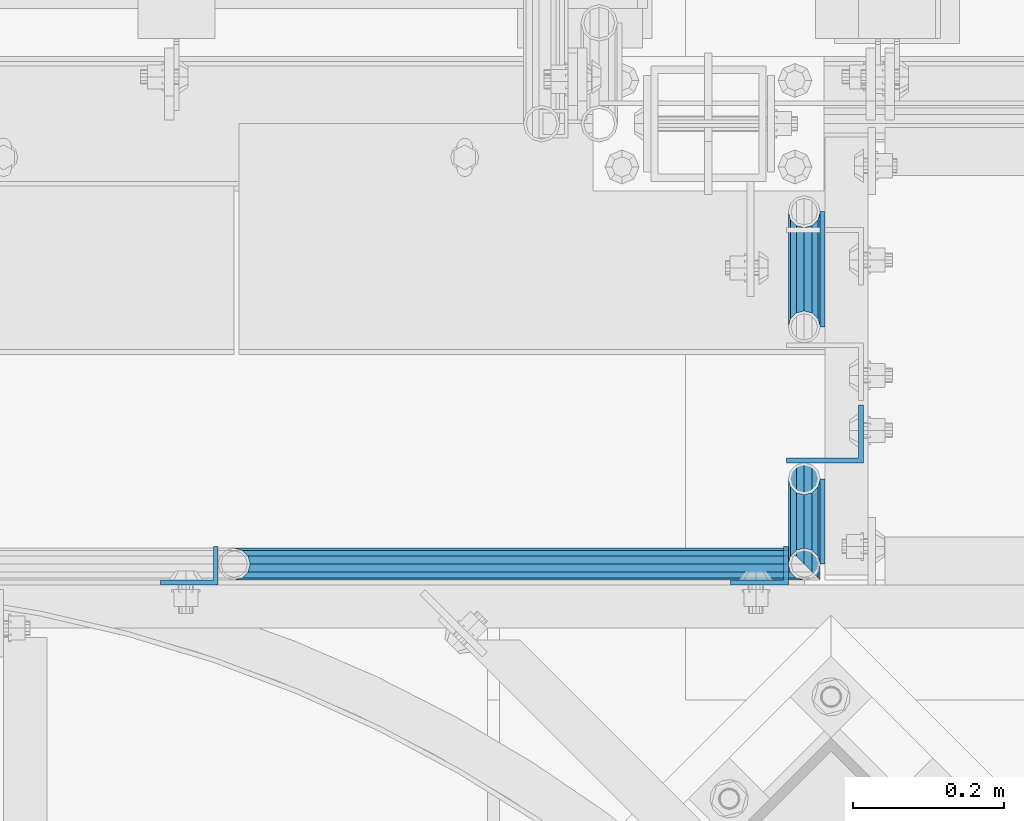
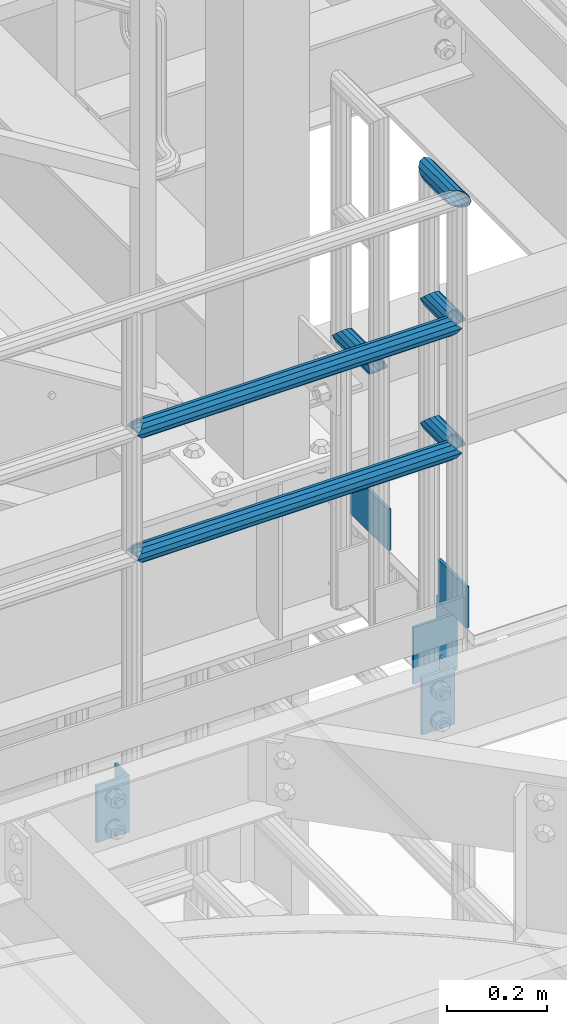
# One storey, part 1150 of 1876: 11 beams, 2 elements without a shape of their own.
"""IFC2X3 building model written with IfcOpenShell, lengths in millimetres."""

from ifc_helpers import new_model, si_unit, frame, origin_with_axes, place, context, subcontext, project, spatial, faceted_brep, material, type_object, element, aggregate, save


model = new_model("IFC2X3")

# Units and contexts
model_context = context("Model", 3, precision=1e-05, world=origin_with_axes())
body_context = subcontext(model_context, "Body", "Model", "MODEL_VIEW")
ifc_project = project(units=[si_unit("LENGTHUNIT", "METRE", prefix="MILLI"), si_unit("AREAUNIT", "SQUARE_METRE"), si_unit("VOLUMEUNIT", "CUBIC_METRE"), si_unit("MASSUNIT", "GRAM", prefix="KILO"), si_unit("TIMEUNIT", "SECOND"), si_unit("PLANEANGLEUNIT", "RADIAN"), si_unit("SOLIDANGLEUNIT", "STERADIAN"), si_unit("THERMODYNAMICTEMPERATUREUNIT", "DEGREE_CELSIUS"), si_unit("LUMINOUSINTENSITYUNIT", "LUMEN")], contexts=[model_context])

# Site, building, storey
site_placement = place(None, origin_with_axes())
site = spatial("IfcSite", under=ifc_project, at=site_placement, CompositionType="ELEMENT")
building_placement = place(site_placement, origin_with_axes())
building = spatial("IfcBuilding", under=site, at=building_placement, Name="Undefined", CompositionType="ELEMENT")
storey_placement = place(building_placement, origin_with_axes())
storey = spatial("IfcBuildingStorey", under=building, at=storey_placement, Name="Undefined", CompositionType="ELEMENT", Elevation=0.0)

# Assembly, beams
assembly_1_placement = place(storey_placement, origin_with_axes())
assembly_1 = element("IfcElementAssembly", 1, at=assembly_1_placement, inside=storey, Name="HANDRAIL", AssemblyPlace="NOTDEFINED", PredefinedType="RIGID_FRAME")
ifc_material_1 = material()
beam_type_1 = type_object("IfcBeamType", Name="PIPE1-1/4STD", PredefinedType="NOTDEFINED")
beam_1_placement = place(assembly_1_placement, frame((5791.20474593762, -7694.13240429563, 8480.425), z_axis=(0.0, 0.0, 1.0), x_axis=(1.0, 0.0, 0.0)))
beam_1 = element("IfcBeam", 2, at=beam_1_placement, type_object=beam_type_1, material=ifc_material_1, Name="RAIL", ObjectType="PIPE1-1/4STD", context=body_context, shape_type="Brep", body=[
    faceted_brep([(735.355706499795, -10.5410000000002, 18.2575475625836), (735.355706499795, -10.5410000000002, 13.3999612267253), (734.879292835652, -8.76299999999992, 15.1779612267255), (732.531254062378, 0.0, 17.5259999999998), (732.531254062378, 0.0, 21.0820000000003), (734.879292835652, 8.76299999999992, 15.1779612267255), (735.355706499795, 10.5410000000002, 13.3999612267253), (735.355706499795, 10.5410000000002, 18.2575475625836), (753.613254062378, 21.0820000000003, 0.0), (743.072254062378, 18.2575475625836, 10.5409999999993), (743.072254062378, 18.2575475625836, -10.5409999999993), (739.992667726521, 15.1779612267264, 8.76300000000083), (742.340706499795, 17.5259999999998, 0.0), (739.992667726521, 15.1779612267264, -8.76300000000083), (735.355706499795, 10.5410000000002, -13.3999612267253), (735.355706499795, 10.5410000000002, -18.2575475625836), (734.879292835652, 8.76299999999992, -15.1779612267255), (732.531254062378, 0.0, -17.5259999999998), (732.531254062378, 0.0, -21.0820000000003), (735.355706499795, -10.5410000000002, -13.3999612267253), (735.355706499795, -10.5410000000002, -18.2575475625836), (734.879292835652, -8.76299999999992, -15.1779612267255), (753.613254062378, -21.0820000000003, 0.0), (743.072254062378, -18.2575475625836, -10.5409999999993), (743.072254062378, -18.2575475625836, 10.5409999999993), (739.992667726521, -15.1779612267264, -8.76300000000083), (742.340706499795, -17.5259999999998, 0.0), (739.992667726521, -15.1779612267264, 8.76300000000083), (10.5409999957128, -18.2575475672238, -10.5409999999993), (18.2575475625817, -10.5410000000011, -18.2575475625836), (9.09494701772928e-13, 21.0820000000003, 0.0), (10.5409999957128, 18.2575475579433, -10.5409999999993), (10.5409999999983, 18.2575475625836, 10.5410000000011), (18.2575475625817, 10.5409999999993, 18.2575475625836), (21.0819999999985, 1.81898940354586e-12, 21.0820000000003), (18.2575475625817, 10.5409999999993, -18.2575475625836), (21.0819999999985, 0.0, -21.0819999999985), (21.0819999999985, 0.0, -17.5259999999998), (18.2575475625817, -10.5409999999974, -13.3999612267271), (18.7339612267233, -8.76300000000083, -15.1779612267255), (18.7339612267251, 8.76299999999901, -15.1779612267255), (18.2575475625817, 10.5410000000011, -13.3999612267235), (13.6205863358573, 15.1779612267255, -8.76299999999901), (11.2725475625839, 17.5259999999998, 0.0), (13.6205863358573, 15.1779612267255, 8.76300000000083), (18.2575475625817, 10.5410000000011, 13.3999612267253), (18.7339612267251, 8.76299999999901, 15.1779612267273), (21.0819999999985, 1.81898940354586e-12, 17.5259999999998), (18.7339612267233, -8.76300000000083, 15.1779612267273), (18.2575475625817, -10.5409999999974, 13.3999612267289), (18.2575475625817, -10.5410000000011, 18.2575475625836), (10.5409999999983, -18.2575475625836, 10.5410000000011), (9.09494701772928e-13, -21.0820000000003, 0.0), (13.6205863358537, -15.1779612267255, 8.76300000000083), (11.2725475625793, -17.5259999999998, 0.0), (13.6205863358537, -15.1779612267255, -8.76299999999901)], [[[0, 1, 2, 3, 4]], [[4, 3, 5, 6, 7]], [[8, 9, 10]], [[7, 6, 11, 12, 13, 14, 15, 10, 9]], [[16, 17, 18, 15, 14]], [[19, 20, 18, 17, 21]], [[22, 23, 24]], [[24, 23, 20, 19, 25, 26, 27, 1, 0]], [[28, 29, 20, 23]], [[30, 31, 32]], [[33, 34, 4, 7]], [[32, 33, 7, 9]], [[30, 32, 9, 8]], [[31, 30, 8, 10]], [[35, 31, 10, 15]], [[36, 35, 15, 18]], [[29, 36, 18, 20]], [[37, 36, 29, 38, 39]], [[40, 41, 35, 36, 37]], [[32, 31, 35, 41, 42, 43, 44, 45, 33]], [[33, 45, 46, 47, 34]], [[34, 47, 48, 49, 50]], [[34, 50, 0, 4]], [[50, 51, 24, 0]], [[51, 52, 22, 24]], [[52, 28, 23, 22]], [[51, 28, 52]], [[50, 49, 53, 54, 55, 38, 29, 28, 51]], [[55, 54, 26, 25]], [[21, 39, 38, 55, 25, 19]], [[37, 39, 21, 17]], [[40, 37, 17, 16]], [[42, 41, 40, 16, 14, 13]], [[43, 42, 13, 12]], [[44, 43, 12, 11]], [[5, 46, 45, 44, 11, 6]], [[47, 46, 5, 3]], [[48, 47, 3, 2]], [[53, 49, 48, 2, 1, 27]], [[54, 53, 27, 26]]]),
])
beam_2_placement = place(assembly_1_placement, frame((6544.818, -7694.13240429563, 8785.225), z_axis=(0.0, 0.0, -1.0), x_axis=(-1.0, 0.0, 0.0)))
beam_2 = element("IfcBeam", 3, at=beam_2_placement, type_object=beam_type_1, material=ifc_material_1, Name="RAIL", ObjectType="PIPE1-1/4STD", context=body_context, shape_type="Brep", body=[
    faceted_brep([(9.09494701772928e-13, 21.0820000000003, 0.0), (10.5409999957128, 18.2575475579433, -10.5409999999993), (10.5409999999983, 18.2575475625836, 10.5410000000011), (10.5409999999983, -18.2575475625836, 10.5410000000011), (10.5409999957128, -18.2575475672238, -10.5409999999993), (9.09494701772928e-13, -21.0820000000003, 0.0), (18.2575475625817, -10.5410000000011, 18.2575475625836), (18.2575475625817, -10.5409999999974, 13.3999612267289), (13.6205863358537, -15.1779612267255, 8.76300000000083), (11.2725475625793, -17.5259999999998, 0.0), (13.6205863358537, -15.1779612267255, -8.76299999999901), (18.2575475625817, -10.5409999999974, -13.3999612267271), (18.2575475625817, -10.5410000000011, -18.2575475625836), (21.0819999999985, 0.0, -17.5259999999998), (21.0819999999985, 0.0, -21.0819999999985), (18.7339612267233, -8.76300000000083, -15.1779612267255), (18.7339612267251, 8.76299999999901, -15.1779612267255), (18.2575475625817, 10.5410000000011, -13.3999612267235), (18.2575475625817, 10.5409999999993, -18.2575475625836), (13.6205863358573, 15.1779612267255, -8.76299999999901), (11.2725475625839, 17.5259999999998, 0.0), (13.6205863358573, 15.1779612267255, 8.76300000000083), (18.2575475625817, 10.5410000000011, 13.3999612267253), (18.2575475625817, 10.5409999999993, 18.2575475625836), (18.7339612267251, 8.76299999999901, 15.1779612267273), (21.0819999999985, 1.81898940354586e-12, 17.5259999999998), (21.0819999999985, 1.81898940354586e-12, 21.0820000000003), (18.7339612267233, -8.76300000000083, 15.1779612267273), (753.613254062378, 21.0820000000003, 0.0), (743.072254062378, 18.2575475625836, -10.5409999999993), (735.355706499795, 10.5410000000002, -18.2575475625836), (753.613254062378, -21.0820000000003, 0.0), (743.072254062378, -18.2575475625836, -10.5409999999993), (743.072254062378, -18.2575475625836, 10.5409999999993), (735.355706499795, -10.5410000000002, 18.2575475625836), (735.355706499795, -10.5410000000002, -18.2575475625836), (732.531254062378, 0.0, -21.0820000000003), (734.879292835652, 8.76299999999992, -15.1779612267255), (732.531254062378, 0.0, -17.5259999999998), (735.355706499795, 10.5410000000002, -13.3999612267253), (735.355706499795, -10.5410000000002, -13.3999612267253), (734.879292835652, -8.76299999999992, -15.1779612267255), (739.992667726521, -15.1779612267264, -8.76300000000083), (742.340706499795, -17.5259999999998, 0.0), (739.992667726521, -15.1779612267264, 8.76300000000083), (735.355706499795, -10.5410000000002, 13.3999612267253), (734.879292835652, -8.76299999999992, 15.1779612267255), (732.531254062378, 0.0, 17.5259999999998), (732.531254062378, 0.0, 21.0820000000003), (735.355706499795, 10.5410000000002, 18.2575475625836), (743.072254062378, 18.2575475625836, 10.5409999999993), (735.355706499795, 10.5410000000002, 13.3999612267253), (739.992667726521, 15.1779612267264, 8.76300000000083), (742.340706499795, 17.5259999999998, 0.0), (739.992667726521, 15.1779612267264, -8.76300000000083), (734.879292835652, 8.76299999999992, 15.1779612267255)], [[[0, 1, 2]], [[3, 4, 5]], [[6, 7, 8, 9, 10, 11, 12, 4, 3]], [[13, 14, 12, 11, 15]], [[16, 17, 18, 14, 13]], [[2, 1, 18, 17, 19, 20, 21, 22, 23]], [[23, 22, 24, 25, 26]], [[26, 25, 27, 7, 6]], [[1, 0, 28, 29]], [[18, 1, 29, 30]], [[31, 32, 33]], [[6, 3, 33, 34]], [[3, 5, 31, 33]], [[5, 4, 32, 31]], [[4, 12, 35, 32]], [[12, 14, 36, 35]], [[14, 18, 30, 36]], [[37, 38, 36, 30, 39]], [[40, 35, 36, 38, 41]], [[33, 32, 35, 40, 42, 43, 44, 45, 34]], [[34, 45, 46, 47, 48]], [[26, 6, 34, 48]], [[2, 23, 49, 50]], [[23, 26, 48, 49]], [[0, 2, 50, 28]], [[28, 50, 29]], [[49, 51, 52, 53, 54, 39, 30, 29, 50]], [[48, 47, 55, 51, 49]], [[25, 24, 55, 47]], [[55, 24, 22, 21, 52, 51]], [[21, 20, 53, 52]], [[20, 19, 54, 53]], [[19, 17, 16, 37, 39, 54]], [[16, 13, 38, 37]], [[13, 15, 41, 38]], [[41, 15, 11, 10, 42, 40]], [[10, 9, 43, 42]], [[9, 8, 44, 43]], [[8, 7, 27, 46, 45, 44]], [[27, 25, 47, 46]]]),
])
beam_3_placement = place(assembly_1_placement, frame((6544.81341817141, -7694.215625, 8480.42499999999), z_axis=(0.0, 0.0, -1.0), x_axis=(0.0, 1.0, 0.0)))
beam_3 = element("IfcBeam", 4, at=beam_3_placement, type_object=beam_type_1, material=ifc_material_1, Name="RAIL", ObjectType="PIPE1-1/4STD", context=body_context, shape_type="Brep", body=[
    faceted_brep([(94.5399051925961, -10.5410000000002, 18.2575475625836), (94.5399051925961, -10.5354181714065, 13.4055430553199), (94.0649871749174, -8.76299999999992, 15.1779612267255), (91.7157205279746, 0.00105404684563837, 17.5259999999998), (91.7157205279746, 0.00105404684563837, 21.0820000000003), (94.0625317803742, 8.76299999999992, 15.1779612267255), (94.5399051925961, 10.5445818285934, 13.3963793981329), (94.5399051925961, 10.5410000000002, 18.2575475625836), (112.795720704372, 21.0820000000003, 0.0), (102.255720704372, 18.2575475625836, 10.5409999999993), (102.255720704372, 18.2575475625836, -10.5409999999993), (99.1732845907281, 15.1779612267264, 8.76300000000083), (101.521323364002, 17.5259999999998, 0.0), (99.1732845907281, 15.1779612267264, -8.76300000000083), (94.5399051925961, 10.5445818285934, -13.3963793981329), (94.5399051925961, 10.5410000000002, -18.2575475625836), (94.0625317803742, 8.76299999999992, -15.1779612267255), (91.715720704372, 0.0, -17.5259999999998), (91.715720704372, 0.0, -21.0820000000003), (94.5399051925961, -10.5354181714065, -13.4055430553199), (94.5399051925961, -10.5410000000002, -18.2575475625836), (94.0649871749174, -8.76299999999992, -15.1779612267255), (112.795720704372, -21.0754181714065, 0.0), (102.255720704372, -18.2575475625836, -10.5409999999993), (102.255720704372, -18.2575475625836, 10.5409999999993), (99.1824482479151, -15.1779612267264, -8.76300000000083), (101.530487021189, -17.5259999999998, 0.0), (99.1824482479151, -15.1779612267264, 8.76300000000083), (10.6232207043722, -18.2575475625836, -10.5409999999993), (18.3390362161481, -10.5410000000002, -18.2575475625836), (0.0832207043722519, 21.0820000000003, 0.0), (10.6232207043722, 18.2575475625836, -10.5409999999993), (10.6232207043722, 18.2575475625836, 10.5409999999993), (18.3390362161481, 10.5410000000002, 18.2575475625836), (21.1632207043722, 0.00458182859347289, 21.0820000000003), (18.3390362161481, 10.5410000000002, -18.2575475625836), (21.1632207043722, 0.0, -21.0820000000003), (21.1632207043722, 0.0, -17.5259999999998), (18.3390362161481, -10.5354181714065, -13.4055430553199), (18.8139542338267, -8.76299999999992, -15.1779612267255), (18.8164096283699, 8.76299999999992, -15.1779612267255), (18.3390362161481, 10.5445818285934, -13.3963793981329), (13.705656818016, 15.1779612267264, -8.76300000000083), (11.3576180447417, 17.5259999999998, 0.0), (13.705656818016, 15.1779612267264, 8.76300000000083), (18.3390362161481, 10.5445818285934, 13.3963793981329), (18.8164096283699, 8.76299999999992, 15.1779612267255), (21.1632207043722, 0.00458182859347289, 17.5259999999998), (18.8139542338267, -8.76299999999992, 15.1779612267255), (18.3390362161481, -10.5354181714065, 13.4055430553199), (18.3390362161481, -10.5410000000002, 18.2575475625836), (10.6232207043722, -18.2575475625836, 10.5409999999993), (0.0832207043722519, -21.0820000000003, 0.0), (13.696493160829, -15.1779612267264, 8.76300000000083), (11.3484543875547, -17.5259999999998, 0.0), (13.696493160829, -15.1779612267264, -8.76300000000083)], [[[0, 1, 2, 3, 4]], [[4, 3, 5, 6, 7]], [[8, 9, 10]], [[7, 6, 11, 12, 13, 14, 15, 10, 9]], [[16, 17, 18, 15, 14]], [[19, 20, 18, 17, 21]], [[22, 23, 24]], [[24, 23, 20, 19, 25, 26, 27, 1, 0]], [[28, 29, 20, 23]], [[30, 31, 32]], [[33, 34, 4, 7]], [[32, 33, 7, 9]], [[30, 32, 9, 8]], [[31, 30, 8, 10]], [[35, 31, 10, 15]], [[36, 35, 15, 18]], [[29, 36, 18, 20]], [[37, 36, 29, 38, 39]], [[40, 41, 35, 36, 37]], [[32, 31, 35, 41, 42, 43, 44, 45, 33]], [[33, 45, 46, 47, 34]], [[34, 47, 48, 49, 50]], [[34, 50, 0, 4]], [[50, 51, 24, 0]], [[51, 52, 22, 24]], [[52, 28, 23, 22]], [[51, 28, 52]], [[50, 49, 53, 54, 55, 38, 29, 28, 51]], [[55, 54, 26, 25]], [[21, 39, 38, 55, 25, 19]], [[37, 39, 21, 17]], [[40, 37, 17, 16]], [[42, 41, 40, 16, 14, 13]], [[43, 42, 13, 12]], [[44, 43, 12, 11]], [[5, 46, 45, 44, 11, 6]], [[47, 46, 5, 3]], [[48, 47, 3, 2]], [[53, 49, 48, 2, 1, 27]], [[54, 53, 27, 26]]]),
])
beam_4_placement = place(assembly_1_placement, frame((6544.81341817141, -7694.215625, 8785.22499999999), z_axis=(0.0, 0.0, -1.0), x_axis=(0.0, 1.0, 0.0)))
beam_4 = element("IfcBeam", 5, at=beam_4_placement, type_object=beam_type_1, material=ifc_material_1, Name="RAIL", ObjectType="PIPE1-1/4STD", context=body_context, shape_type="Brep", body=[
    faceted_brep([(94.5399051925961, -10.5410000000002, 18.2575475625836), (94.5399051925961, -10.5354181714065, 13.4055430553199), (94.0649871749174, -8.76299999999992, 15.1779612267255), (91.7157205279746, 0.00105404684563837, 17.5259999999998), (91.7157205279746, 0.00105404684563837, 21.0820000000003), (94.0625317803742, 8.76299999999992, 15.1779612267255), (94.5399051925961, 10.5445818285934, 13.3963793981329), (94.5399051925961, 10.5410000000002, 18.2575475625836), (112.795720704372, 21.0820000000003, 0.0), (102.255720704372, 18.2575475625836, 10.5409999999993), (102.255720704372, 18.2575475625836, -10.5409999999993), (99.1732845907281, 15.1779612267264, 8.76300000000083), (101.521323364002, 17.5259999999998, 0.0), (99.1732845907281, 15.1779612267264, -8.76300000000083), (94.5399051925961, 10.5445818285934, -13.3963793981329), (94.5399051925961, 10.5410000000002, -18.2575475625836), (94.0625317803742, 8.76299999999992, -15.1779612267255), (91.715720704372, 0.0, -17.5259999999998), (91.715720704372, 0.0, -21.0820000000003), (94.5399051925961, -10.5354181714065, -13.4055430553199), (94.5399051925961, -10.5410000000002, -18.2575475625836), (94.0649871749174, -8.76299999999992, -15.1779612267255), (112.795720704372, -21.0754181714065, 0.0), (102.255720704372, -18.2575475625836, -10.5409999999993), (102.255720704372, -18.2575475625836, 10.5409999999993), (99.1824482479151, -15.1779612267264, -8.76300000000083), (101.530487021189, -17.5259999999998, 0.0), (99.1824482479151, -15.1779612267264, 8.76300000000083), (10.6232207043722, -18.2575475625836, -10.5409999999993), (18.3390362161481, -10.5410000000002, -18.2575475625836), (0.0832207043722519, 21.0820000000003, 0.0), (10.6232207043722, 18.2575475625836, -10.5409999999993), (10.6232207043722, 18.2575475625836, 10.5409999999993), (18.3390362161481, 10.5410000000002, 18.2575475625836), (21.1632207043722, 0.00458182859347289, 21.0820000000003), (18.3390362161481, 10.5410000000002, -18.2575475625836), (21.1632207043722, 0.0, -21.0820000000003), (21.1632207043722, 0.0, -17.5259999999998), (18.3390362161481, -10.5354181714065, -13.4055430553199), (18.8139542338267, -8.76299999999992, -15.1779612267255), (18.8164096283699, 8.76299999999992, -15.1779612267255), (18.3390362161481, 10.5445818285934, -13.3963793981329), (13.705656818016, 15.1779612267264, -8.76300000000083), (11.3576180447417, 17.5259999999998, 0.0), (13.705656818016, 15.1779612267264, 8.76300000000083), (18.3390362161481, 10.5445818285934, 13.3963793981329), (18.8164096283699, 8.76299999999992, 15.1779612267255), (21.1632207043722, 0.00458182859347289, 17.5259999999998), (18.8139542338267, -8.76299999999992, 15.1779612267255), (18.3390362161481, -10.5354181714065, 13.4055430553199), (18.3390362161481, -10.5410000000002, 18.2575475625836), (10.6232207043722, -18.2575475625836, 10.5409999999993), (0.0832207043722519, -21.0820000000003, 0.0), (13.696493160829, -15.1779612267264, 8.76300000000083), (11.3484543875547, -17.5259999999998, 0.0), (13.696493160829, -15.1779612267264, -8.76300000000083)], [[[0, 1, 2, 3, 4]], [[4, 3, 5, 6, 7]], [[8, 9, 10]], [[7, 6, 11, 12, 13, 14, 15, 10, 9]], [[16, 17, 18, 15, 14]], [[19, 20, 18, 17, 21]], [[22, 23, 24]], [[24, 23, 20, 19, 25, 26, 27, 1, 0]], [[28, 29, 20, 23]], [[30, 31, 32]], [[33, 34, 4, 7]], [[32, 33, 7, 9]], [[30, 32, 9, 8]], [[31, 30, 8, 10]], [[35, 31, 10, 15]], [[36, 35, 15, 18]], [[29, 36, 18, 20]], [[37, 36, 29, 38, 39]], [[40, 41, 35, 36, 37]], [[32, 31, 35, 41, 42, 43, 44, 45, 33]], [[33, 45, 46, 47, 34]], [[34, 47, 48, 49, 50]], [[34, 50, 0, 4]], [[50, 51, 24, 0]], [[51, 52, 22, 24]], [[52, 28, 23, 22]], [[51, 28, 52]], [[50, 49, 53, 54, 55, 38, 29, 28, 51]], [[55, 54, 26, 25]], [[21, 39, 38, 55, 25, 19]], [[37, 39, 21, 17]], [[40, 37, 17, 16]], [[42, 41, 40, 16, 14, 13]], [[43, 42, 13, 12]], [[44, 43, 12, 11]], [[5, 46, 45, 44, 11, 6]], [[47, 46, 5, 3]], [[48, 47, 3, 2]], [[53, 49, 48, 2, 1, 27]], [[54, 53, 27, 26]]]),
])
beam_5_placement = place(assembly_1_placement, frame((6544.81341817141, -7694.13240429563, 9090.02499999999), z_axis=(0.0, 0.0, -1.0), x_axis=(0.0, 1.0, 0.0)))
beam_5 = element("IfcBeam", 6, at=beam_5_placement, type_object=beam_type_1, material=ifc_material_1, Name="RAIL", ObjectType="PIPE1-1/4STD", context=body_context, shape_type="Brep", body=[
    faceted_brep([(17.5259999999998, -17.5259999999998, 0.0), (15.1779612267264, -15.1779612267264, 8.76300000000083), (103.9495, -15.1779612267264, 8.76300000000083), (112.7125, -17.5259999999998, 0.0), (8.76299999999992, -8.76299999999992, 15.1779612267255), (97.5345387732732, -8.76299999999992, 15.1779612267255), (0.0, 0.0, 17.5259999999998), (95.1864999999998, 0.0, 17.5259999999998), (-8.76299999999992, 8.76299999999992, 15.1779612267255), (97.5345387732732, 8.76299999999992, 15.1779612267255), (-15.1779612267264, 15.1779612267264, 8.76300000000083), (103.9495, 15.1779612267264, 8.76300000000083), (-17.5259999999998, 17.5259999999998, 0.0), (112.7125, 17.5259999999998, 0.0), (-15.1779612267264, 15.1779612267264, -8.76300000000083), (121.4755, 15.1779612267264, -8.76300000000083), (-8.76299999999992, 8.76299999999992, -15.1779612267255), (127.890461226726, 8.76299999999992, -15.1779612267255), (0.0, 0.0, -17.5259999999998), (130.238499999999, 0.0, -17.5259999999998), (8.76299999999992, -8.76299999999992, -15.1779612267255), (127.890461226726, -8.76299999999992, -15.1779612267255), (15.1779612267264, -15.1779612267264, -8.76300000000083), (121.4755, -15.1779612267264, -8.76300000000083), (21.0819999957121, -21.0820000092799, 0.0), (18.2575475625836, -18.2575475625836, -10.5409999999993), (123.2535, -18.2575475625836, -10.5409999999993), (112.7125, -21.0820000000003, 0.0), (10.5410000000002, -10.5410000000002, -18.2575475625836), (130.970047562583, -10.5410000000002, -18.2575475625836), (-4.28826751885936e-09, 0.0, -21.0820000000003), (133.7945, 0.0, -21.0820000000003), (-10.5410000000002, 10.5410000000002, -18.2575475625836), (130.970047562583, 10.5410000000002, -18.2575475625836), (-18.2575475625836, 18.2575475625836, -10.5409999999993), (123.2535, 18.2575475625836, -10.5409999999993), (-21.0820000000003, 21.0820000000003, 0.0), (112.7125, 21.0820000000003, 0.0), (-18.2575475625836, 18.2575475625836, 10.5409999999993), (102.171499999999, 18.2575475625836, 10.5409999999993), (-10.5410000000002, 10.5410000000002, 18.2575475625836), (94.4549524374161, 10.5410000000002, 18.2575475625836), (0.0, 0.0, 21.0820000000003), (91.6304999999993, 0.0, 21.0820000000003), (10.5410000000002, -10.5410000000002, 18.2575475625836), (94.4549524374161, -10.5410000000002, 18.2575475625836), (18.2575475625836, -18.2575475625836, 10.5409999999993), (102.171499999999, -18.2575475625836, 10.5409999999993)], [[[0, 1, 2, 3]], [[1, 4, 5, 2]], [[4, 6, 7, 5]], [[6, 8, 9, 7]], [[8, 10, 11, 9]], [[10, 12, 13, 11]], [[12, 14, 15, 13]], [[14, 16, 17, 15]], [[16, 18, 19, 17]], [[18, 20, 21, 19]], [[20, 22, 23, 21]], [[22, 0, 3, 23]], [[24, 25, 26, 27]], [[25, 28, 29, 26]], [[28, 30, 31, 29]], [[30, 32, 33, 31]], [[32, 34, 35, 33]], [[34, 36, 37, 35]], [[36, 38, 39, 37]], [[38, 40, 41, 39]], [[40, 42, 43, 41]], [[42, 44, 45, 43]], [[44, 46, 47, 45]], [[46, 24, 27, 47]], [[29, 31, 33, 35, 37, 39, 41, 43, 45, 47, 27, 26], [5, 7, 9, 11, 13, 15, 17, 19, 21, 23, 3, 2]], [[46, 44, 42, 40, 38, 36, 34, 32, 30, 28, 25, 24], [22, 20, 18, 16, 14, 12, 10, 8, 6, 4, 1, 0]]]),
])

assembly_2_placement = place(storey_placement, origin_with_axes())
assembly_2 = element("IfcElementAssembly", 7, at=assembly_2_placement, inside=storey, Name="RAIL", AssemblyPlace="NOTDEFINED", PredefinedType="RIGID_FRAME")
beam_6_placement = place(assembly_2_placement, frame((6544.818, -7380.684375, 8480.42499999999), z_axis=(0.0, 0.0, -1.0), x_axis=(0.0, 1.0, 0.0)))
beam_6 = element("IfcBeam", 8, at=beam_6_placement, type_object=beam_type_1, material=ifc_material_1, Name="RAIL", ObjectType="PIPE1-1/4STD", context=body_context, shape_type="Brep", body=[
    faceted_brep([(134.227405192596, -10.5410000000002, 18.2575475625836), (134.227405192596, -10.54, 13.4009612267255), (133.751259477646, -8.76299999999992, 15.1779612267255), (131.403220704372, 0.0, 17.5259999999998), (131.403220704372, 0.0, 21.0820000000003), (133.751259477646, 8.76299999999992, 15.1779612267255), (134.227405192596, 10.54, 13.4009612267255), (134.227405192596, 10.5410000000002, 18.2575475625836), (152.483220704372, 21.0820000000003, 0.0), (141.943220704372, 18.2575475625836, 10.5409999999993), (141.943220704372, 18.2575475625836, -10.5409999999993), (138.865366419322, 15.1779612267264, 8.76300000000083), (141.213405192596, 17.5259999999998, 0.0), (138.865366419322, 15.1779612267264, -8.76300000000083), (134.227405192596, 10.54, -13.4009612267255), (134.227405192596, 10.5410000000002, -18.2575475625836), (133.751259477646, 8.76299999999992, -15.1779612267255), (131.403220704372, 0.0, -17.5259999999998), (131.403220704372, 0.0, -21.0820000000003), (134.227405192596, -10.54, -13.4009612267255), (134.227405192596, -10.5410000000002, -18.2575475625836), (133.751259477646, -8.76299999999992, -15.1779612267255), (152.483220704372, -21.0799999999999, 0.0), (141.943220704372, -18.2575475625836, -10.5409999999993), (141.943220704372, -18.2575475625836, 10.5409999999993), (138.865366419322, -15.1779612267264, -8.76300000000083), (141.213405192596, -17.5259999999998, 0.0), (138.865366419322, -15.1779612267264, 8.76300000000083), (10.6232207043722, -18.2575475625836, -10.5409999999993), (18.3390362161481, -10.5410000000002, -18.2575475625836), (0.0832207043722519, 21.0820000000003, 0.0), (10.6232207043722, 18.2575475625836, -10.5409999999993), (10.6232207043722, 18.2575475625836, 10.5409999999993), (18.3390362161481, 10.5410000000002, 18.2575475625836), (21.1632207043722, 0.0, 21.0820000000003), (18.3390362161481, 10.5410000000002, -18.2575475625836), (21.1632207043722, 0.0, -21.0820000000003), (21.1632207043722, 0.0, -17.5259999999998), (18.3390362161481, -10.54, -13.4009612267255), (18.8151819310979, -8.76299999999992, -15.1779612267255), (18.8151819310979, 8.76299999999992, -15.1779612267255), (18.3390362161481, 10.54, -13.4009612267255), (13.7010749894225, 15.1779612267264, -8.76300000000083), (11.3530362161482, 17.5259999999998, 0.0), (13.7010749894225, 15.1779612267264, 8.76300000000083), (18.3390362161481, 10.54, 13.4009612267255), (18.8151819310979, 8.76299999999992, 15.1779612267255), (21.1632207043722, 0.0, 17.5259999999998), (18.8151819310979, -8.76299999999992, 15.1779612267255), (18.3390362161481, -10.54, 13.4009612267255), (18.3390362161481, -10.5410000000002, 18.2575475625836), (10.6232207043722, -18.2575475625836, 10.5409999999993), (0.0832207043722519, -21.0820000000003, 0.0), (13.7010749894225, -15.1779612267264, 8.76300000000083), (11.3530362161482, -17.5259999999998, 0.0), (13.7010749894225, -15.1779612267264, -8.76300000000083)], [[[0, 1, 2, 3, 4]], [[4, 3, 5, 6, 7]], [[8, 9, 10]], [[7, 6, 11, 12, 13, 14, 15, 10, 9]], [[16, 17, 18, 15, 14]], [[19, 20, 18, 17, 21]], [[22, 23, 24]], [[24, 23, 20, 19, 25, 26, 27, 1, 0]], [[28, 29, 20, 23]], [[30, 31, 32]], [[33, 34, 4, 7]], [[32, 33, 7, 9]], [[30, 32, 9, 8]], [[31, 30, 8, 10]], [[35, 31, 10, 15]], [[36, 35, 15, 18]], [[29, 36, 18, 20]], [[37, 36, 29, 38, 39]], [[40, 41, 35, 36, 37]], [[32, 31, 35, 41, 42, 43, 44, 45, 33]], [[33, 45, 46, 47, 34]], [[34, 47, 48, 49, 50]], [[34, 50, 0, 4]], [[50, 51, 24, 0]], [[51, 52, 22, 24]], [[52, 28, 23, 22]], [[51, 28, 52]], [[50, 49, 53, 54, 55, 38, 29, 28, 51]], [[55, 54, 26, 25]], [[21, 39, 38, 55, 25, 19]], [[37, 39, 21, 17]], [[40, 37, 17, 16]], [[42, 41, 40, 16, 14, 13]], [[43, 42, 13, 12]], [[44, 43, 12, 11]], [[5, 46, 45, 44, 11, 6]], [[47, 46, 5, 3]], [[48, 47, 3, 2]], [[53, 49, 48, 2, 1, 27]], [[54, 53, 27, 26]]]),
])
ifc_material_2 = material(Name="STEEL/A36")
beam_type_2 = type_object("IfcBeamType", PredefinedType="NOTDEFINED")
beam_7_placement = place(assembly_2_placement, frame((6569.075, -7380.60115429563, 8080.375), z_axis=(0.0, 0.0, 1.0), x_axis=(0.0, 1.0, 0.0)))
beam_7 = element("IfcBeam", 9, at=beam_7_placement, type_object=beam_type_2, material=ifc_material_2, Name="PLATE", context=body_context, shape_type="Brep", body=[
    faceted_brep([(0.0, 3.17500000000018, -50.8000000000002), (0.0, 3.17500000000018, 50.8000000000002), (152.400000000001, 3.17500000000018, 50.8000000000002), (152.400000000001, 3.17500000000018, -50.8000000000002), (0.0, -3.17500000000018, 50.8000000000002), (152.400000000001, -3.17500000000018, 50.8000000000002), (0.0, -3.17500000000018, -50.8000000000002), (152.400000000001, -3.17500000000018, -50.8000000000002)], [[[0, 1, 2, 3]], [[1, 4, 5, 2]], [[4, 6, 7, 5]], [[6, 0, 3, 7]], [[5, 7, 3, 2]], [[6, 4, 1, 0]]]),
])
aggregate(assembly_2, [beam_7, beam_6])

# Beam
beam_8_placement = place(assembly_1_placement, frame((6569.075, -7694.13240429563, 8080.375), z_axis=(0.0, 0.0, 1.0), x_axis=(0.0, 1.0, 0.0)))
beam_8 = element("IfcBeam", 10, at=beam_8_placement, type_object=beam_type_2, material=ifc_material_2, Name="PLATE", context=body_context, shape_type="Brep", body=[
    faceted_brep([(0.0, 3.17500000000018, -50.8000000000002), (0.0, 3.17500000000018, 50.8000000000002), (112.712500000001, 3.17500000000018, 50.8000000000002), (112.712500000001, 3.17500000000018, -50.8000000000002), (0.0, -3.17500000000018, 50.8000000000002), (112.712500000001, -3.17500000000018, 50.8000000000002), (0.0, -3.17500000000018, -50.8000000000002), (112.712500000001, -3.17500000000018, -50.8000000000002)], [[[0, 1, 2, 3]], [[1, 4, 5, 2]], [[4, 6, 7, 5]], [[6, 0, 3, 7]], [[5, 7, 3, 2]], [[6, 4, 1, 0]]]),
])

beam_type_3 = type_object("IfcBeamType", Name="L4X3X1/4", PredefinedType="NOTDEFINED")
beam_9_placement = place(assembly_1_placement, frame((6572.25, -7522.23790429563, 7966.075), z_axis=(-1.0, 0.0, 0.0), x_axis=(0.0, 0.0, -1.0)))
beam_9 = element("IfcBeam", 11, at=beam_9_placement, type_object=beam_type_3, material=ifc_material_2, Name="ANGLE", ObjectType="L4X3X1/4", context=body_context, shape_type="Brep", body=[
    faceted_brep([(0.0, 38.1000000000004, -50.8000000000002), (0.0, 38.1000000000004, 50.8000000000002), (139.7, 38.1000000000004, 50.8000000000002), (139.7, 38.1000000000004, -50.8000000000002), (0.0, 31.75, 50.8000000000002), (139.7, 31.75, 50.8000000000002), (0.0, 31.75, -44.4499999999998), (139.7, 31.75, -44.4499999999998), (0.0, -38.1000000000004, -44.4499999999998), (139.7, -38.1000000000004, -44.4499999999998), (0.0, -38.1000000000004, -50.8000000000002), (139.7, -38.1000000000004, -50.8000000000002)], [[[0, 1, 2, 3]], [[1, 4, 5, 2]], [[4, 6, 7, 5]], [[6, 8, 9, 7]], [[8, 10, 11, 9]], [[10, 0, 3, 11]], [[5, 7, 9, 11, 3, 2]], [[10, 8, 6, 4, 1, 0]]]),
])

beam_type_4 = type_object("IfcBeamType", Name="L3X2X1/4", PredefinedType="NOTDEFINED")
beam_10_placement = place(assembly_1_placement, frame((6485.636, -7696.16440429563, 7966.075), z_axis=(-1.0, 0.0, 0.0), x_axis=(0.0, 0.0, -1.0)))
beam_10 = element("IfcBeam", 12, at=beam_10_placement, type_object=beam_type_4, material=ifc_material_2, Name="ANGLE", ObjectType="L3X2X1/4", context=body_context, shape_type="Brep", body=[
    faceted_brep([(0.0, 25.3999999999996, -38.1000000000004), (0.0, 25.3999999999996, 38.1000000000004), (139.7, 25.3999999999996, 38.1000000000004), (139.7, 25.3999999999996, -38.1000000000004), (0.0, 19.0500000000002, 38.1000000000004), (139.7, 19.0500000000002, 38.1000000000004), (0.0, 19.0500000000002, -31.75), (139.7, 19.0500000000002, -31.75), (0.0, -25.3999999999996, -31.75), (139.7, -25.3999999999996, -31.75), (0.0, -25.3999999999996, -38.1000000000004), (139.7, -25.3999999999996, -38.1000000000004)], [[[0, 1, 2, 3]], [[1, 4, 5, 2]], [[4, 6, 7, 5]], [[6, 8, 9, 7]], [[8, 10, 11, 9]], [[10, 0, 3, 11]], [[5, 7, 9, 11, 3, 2]], [[10, 8, 6, 4, 1, 0]]]),
])

beam_11_placement = place(assembly_1_placement, frame((5732.02274593762, -7696.16440429563, 7966.075), z_axis=(-1.0, 0.0, 0.0), x_axis=(0.0, 0.0, -1.0)))
beam_11 = element("IfcBeam", 13, at=beam_11_placement, type_object=beam_type_4, material=ifc_material_2, Name="ANGLE", ObjectType="L3X2X1/4", context=body_context, shape_type="Brep", body=[
    faceted_brep([(0.0, 25.3999999999996, -38.1000000000004), (0.0, 25.3999999999996, 38.1000000000004), (139.7, 25.3999999999996, 38.1000000000004), (139.7, 25.3999999999996, -38.1000000000004), (0.0, 19.0500000000002, 38.1000000000004), (139.7, 19.0500000000002, 38.1000000000004), (0.0, 19.0500000000002, -31.75), (139.7, 19.0500000000002, -31.75), (0.0, -25.3999999999996, -31.75), (139.7, -25.3999999999996, -31.75), (0.0, -25.3999999999996, -38.1000000000004), (139.7, -25.3999999999996, -38.1000000000004)], [[[0, 1, 2, 3]], [[1, 4, 5, 2]], [[4, 6, 7, 5]], [[6, 8, 9, 7]], [[8, 10, 11, 9]], [[10, 0, 3, 11]], [[5, 7, 9, 11, 3, 2]], [[10, 8, 6, 4, 1, 0]]]),
])

aggregate(assembly_1, [beam_8, beam_9, beam_10, beam_11, beam_1, beam_2, beam_3, beam_4, beam_5])

save(model, "model.ifc")
